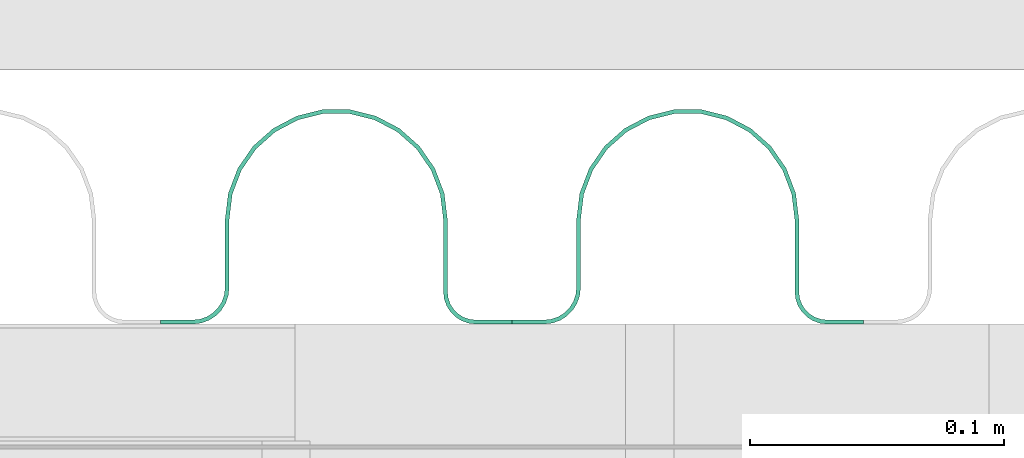
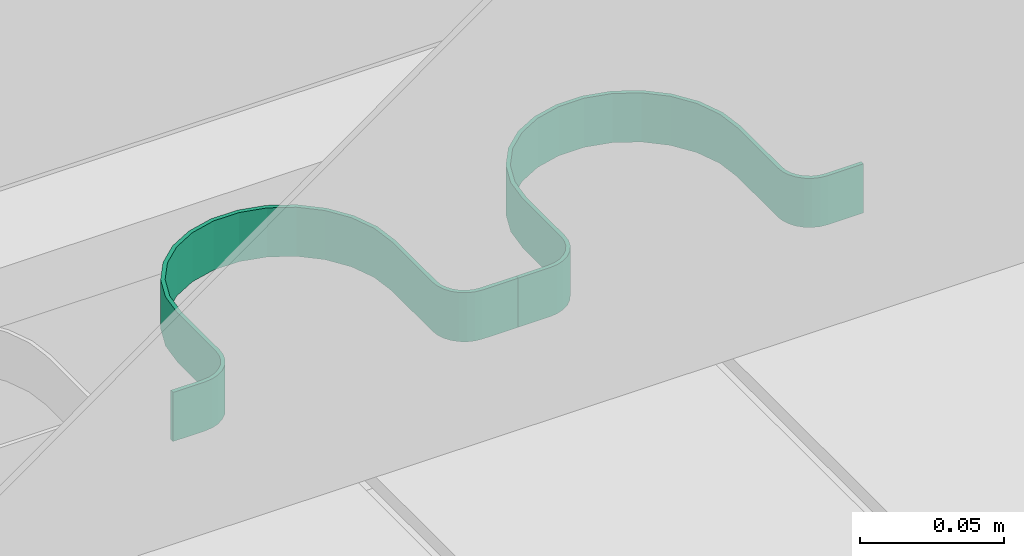
# One storey, part 28 of 33: 2 valves.
"""IFC4 building model written with IfcOpenShell, lengths in feet."""

from ifc_helpers import new_model, entity, si_unit, converted_unit, derived_unit, direction, frame, frame_2d, origin, place, context, subcontext, project, spatial, polyline, circle_curve, parameter, trimmed, segment, composite_curve, outline, extrude, source, transform, mapped, material, type_object, type_shapes, element, save


model = new_model("IFC4")

# Units and contexts
model_context = context("Model", 3, precision=0.0001, world=origin(), true_north=direction((6.12303176911189e-17, 1.0)))
body_context = subcontext(model_context, "Body", "Model", "MODEL_VIEW")
ifc_project = project(units=[converted_unit("LENGTHUNIT", "FOOT", entity("IfcRatioMeasure", 0.3048), si_unit("LENGTHUNIT", "METRE"), dimensions=[1, 0, 0, 0, 0, 0, 0]), converted_unit("AREAUNIT", "SQUARE FOOT", entity("IfcRatioMeasure", 0.09290304), si_unit("AREAUNIT", "SQUARE_METRE"), dimensions=[2, 0, 0, 0, 0, 0, 0]), converted_unit("VOLUMEUNIT", "CUBIC FOOT", entity("IfcRatioMeasure", 0.028316846592), si_unit("VOLUMEUNIT", "CUBIC_METRE"), dimensions=[3, 0, 0, 0, 0, 0, 0]), converted_unit("PLANEANGLEUNIT", "DEGREE", entity("IfcRatioMeasure", 0.0174532925199433), si_unit("PLANEANGLEUNIT", "RADIAN"), dimensions=[0, 0, 0, 0, 0, 0, 0]), si_unit("MASSUNIT", "GRAM", prefix="KILO"), derived_unit("MASSDENSITYUNIT", [(si_unit("MASSUNIT", "GRAM", prefix="KILO"), 1), (si_unit("LENGTHUNIT", "METRE"), -3)]), derived_unit("MOMENTOFINERTIAUNIT", [(si_unit("LENGTHUNIT", "METRE"), 4)]), si_unit("TIMEUNIT", "SECOND"), si_unit("FREQUENCYUNIT", "HERTZ"), si_unit("THERMODYNAMICTEMPERATUREUNIT", "DEGREE_CELSIUS"), derived_unit("THERMALTRANSMITTANCEUNIT", [(si_unit("MASSUNIT", "GRAM", prefix="KILO"), 1), (si_unit("THERMODYNAMICTEMPERATUREUNIT", "KELVIN"), -1), (si_unit("TIMEUNIT", "SECOND"), -3)]), derived_unit("VOLUMETRICFLOWRATEUNIT", [(si_unit("LENGTHUNIT", "METRE"), 3), (si_unit("TIMEUNIT", "SECOND"), -1)]), si_unit("ELECTRICCURRENTUNIT", "AMPERE"), si_unit("ELECTRICVOLTAGEUNIT", "VOLT"), si_unit("POWERUNIT", "WATT"), si_unit("FORCEUNIT", "NEWTON"), si_unit("ILLUMINANCEUNIT", "LUX"), si_unit("LUMINOUSFLUXUNIT", "LUMEN"), si_unit("LUMINOUSINTENSITYUNIT", "CANDELA"), derived_unit("USERDEFINED", [(si_unit("MASSUNIT", "GRAM", prefix="KILO"), -1), (si_unit("LENGTHUNIT", "METRE"), -2), (si_unit("TIMEUNIT", "SECOND"), 3), (si_unit("LUMINOUSFLUXUNIT", "LUMEN"), 1)]), derived_unit("LINEARVELOCITYUNIT", [(si_unit("LENGTHUNIT", "METRE"), 1), (si_unit("TIMEUNIT", "SECOND"), -1)]), si_unit("PRESSUREUNIT", "PASCAL"), derived_unit("USERDEFINED", [(si_unit("LENGTHUNIT", "METRE"), -2), (si_unit("MASSUNIT", "GRAM", prefix="KILO"), 1), (si_unit("TIMEUNIT", "SECOND"), -2)]), derived_unit("LINEARFORCEUNIT", [(si_unit("MASSUNIT", "GRAM", prefix="KILO"), 1), (si_unit("LENGTHUNIT", "METRE"), 1), (si_unit("TIMEUNIT", "SECOND"), -2), (si_unit("LENGTHUNIT", "METRE"), -1)]), derived_unit("PLANARFORCEUNIT", [(si_unit("MASSUNIT", "GRAM", prefix="KILO"), 1), (si_unit("LENGTHUNIT", "METRE"), 1), (si_unit("TIMEUNIT", "SECOND"), -2), (si_unit("LENGTHUNIT", "METRE"), -2)])], contexts=[model_context])

# Site, building, storey
site_placement = place(None, origin())
site = spatial("IfcSite", under=ifc_project, at=site_placement, CompositionType="ELEMENT")
building_placement = place(site_placement, origin())
building = spatial("IfcBuilding", under=site, at=building_placement, CompositionType="ELEMENT")
storey_placement = place(building_placement, frame((0.0, 0.0, 10.0)))
storey = spatial("IfcBuildingStorey", under=building, at=storey_placement, Name="2ND FLOOR", CompositionType="ELEMENT", Elevation=10.0000000000002)

# Valves
ifc_material = material(Name="GALV. U BRACKET AT GALV. PIPE", Category="Materials")
valve_type_1 = type_object("IfcValveType", Name="U BRACKET5:U BRACKET", PredefinedType="NOTDEFINED", material=ifc_material)
shared_shape_1 = source(origin(), body_context, "Body", "SweptSolid", [
    extrude(outline(composite_curve([segment(polyline([(0.0407648216664178, -0.226295029472567), (0.0459731549997509, -0.226295029472567)]), True, "CONTINUOUS"), segment(polyline([(0.0459731549997509, -0.226295029472567), (0.0459731549997509, -0.184628362805825)]), True, "CONTINUOUS"), segment(trimmed(circle_curve(frame_2d((-0.000901845000249146, -0.184628362805825), x_axis=(0.0, 1.0)), 0.046875), [parameter(270.0)], [parameter(2.03555499613665e-13)], True, "PARAMETER"), True, "CONTINUOUS"), segment(polyline([(-0.000901845000249146, -0.137753362805825), (-0.0884402983327046, -0.137753362805825)]), True, "CONTINUOUS"), segment(trimmed(circle_curve(frame_2d((-0.0884402983327037, 0.000651041666515084), x_axis=(0.0, 1.0)), 0.138404404472415), [parameter(2.03555499613665e-13)], [parameter(180.0)], True, "PARAMETER"), False, "CONTINUOUS"), segment(polyline([(-0.0884402983327037, 0.139055446138855), (0.00430648833316294, 0.139055446138855)]), True, "CONTINUOUS"), segment(trimmed(circle_curve(frame_2d((0.00430648833316294, 0.180722112805597), x_axis=(0.0, 1.0)), 0.0416666666666667), [parameter(180.0)], [parameter(270.0)], True, "PARAMETER"), True, "CONTINUOUS"), segment(polyline([(0.0459731549998299, 0.180722112805597), (0.0459731549998308, 0.227597112805597)]), True, "CONTINUOUS"), segment(polyline([(0.0459731549998308, 0.227597112805597), (0.0407648216664969, 0.227597112805597)]), True, "CONTINUOUS"), segment(polyline([(0.0407648216664969, 0.227597112805597), (0.0407648216664969, 0.180722112805597)]), True, "CONTINUOUS"), segment(trimmed(circle_curve(frame_2d((0.00430648833316294, 0.180722112805597), x_axis=(0.0, 1.0)), 0.0364583333333333), [parameter(180.0)], [parameter(270.0)], True, "PARAMETER"), False, "CONTINUOUS"), segment(polyline([(0.00430648833316294, 0.14426377947234), (-0.0884402983327028, 0.14426377947234)]), True, "CONTINUOUS"), segment(trimmed(circle_curve(frame_2d((-0.0884402983327037, 0.000651041666515084), x_axis=(0.0, 1.0)), 0.143612737805749), [parameter(360.0)], [parameter(180.0)], True, "PARAMETER"), True, "CONTINUOUS"), segment(polyline([(-0.0884402983327055, -0.142961696139309), (-0.000901845000249146, -0.142961696139309)]), True, "CONTINUOUS"), segment(trimmed(circle_curve(frame_2d((-0.000901845000249146, -0.184628362805825), x_axis=(0.0, 1.0)), 0.0416666666666667), [parameter(270.0)], [parameter(2.03555499613665e-13)], True, "PARAMETER"), False, "CONTINUOUS"), segment(polyline([(0.0407648216664178, -0.184628362805825), (0.0407648216664178, -0.226295029472567)]), True, "CONTINUOUS")], self_intersect=False)), frame((0.226295029472567, 0.0512069877948296, 0.0), z_axis=(0.0, 0.0, 1.0), x_axis=(0.0, -1.0, 0.0)), (0.0, 0.0, 1.0), 0.0683255255426953),
])
type_shapes(valve_type_1, [shared_shape_1])
valve_1_placement = place(storey_placement, frame((1490.40255519649, 4.11092510371606, 0.757393194068698)))
element("IfcValve", 1, at=valve_1_placement, inside=storey, type_object=valve_type_1, material=ifc_material, Name="U BRACKET5:U BRACKET", ObjectType="U BRACKET5:U BRACKET", PredefinedType="NOTDEFINED", context=body_context, shape_type="MappedRepresentation", body=[
    mapped(shared_shape_1, transform((0.0, 0.0, 0.0), scale=1.0)),
])
valve_type_2 = type_object("IfcValveType", Name="U BRACKET7:U BRACKET", PredefinedType="NOTDEFINED", material=ifc_material)
shared_shape_2 = source(origin(), body_context, "Body", "SweptSolid", [
    extrude(outline(composite_curve([segment(polyline([(0.0407648216664178, -0.226295029472567), (0.0459731549997509, -0.226295029472567)]), True, "CONTINUOUS"), segment(polyline([(0.0459731549997509, -0.226295029472567), (0.0459731549997509, -0.184628362805825)]), True, "CONTINUOUS"), segment(trimmed(circle_curve(frame_2d((-0.000901845000249146, -0.184628362805825), x_axis=(0.0, 1.0)), 0.046875), [parameter(270.0)], [parameter(2.03555499613665e-13)], True, "PARAMETER"), True, "CONTINUOUS"), segment(polyline([(-0.000901845000249146, -0.137753362805825), (-0.0884402983327046, -0.137753362805825)]), True, "CONTINUOUS"), segment(trimmed(circle_curve(frame_2d((-0.0884402983327037, 0.000651041666515084), x_axis=(0.0, 1.0)), 0.138404404472415), [parameter(2.03555499613665e-13)], [parameter(180.0)], True, "PARAMETER"), False, "CONTINUOUS"), segment(polyline([(-0.0884402983327037, 0.139055446138855), (0.00430648833316294, 0.139055446138855)]), True, "CONTINUOUS"), segment(trimmed(circle_curve(frame_2d((0.00430648833316294, 0.180722112805597), x_axis=(0.0, 1.0)), 0.0416666666666667), [parameter(180.0)], [parameter(270.0)], True, "PARAMETER"), True, "CONTINUOUS"), segment(polyline([(0.0459731549998299, 0.180722112805597), (0.0459731549998308, 0.227597112805597)]), True, "CONTINUOUS"), segment(polyline([(0.0459731549998308, 0.227597112805597), (0.0407648216664969, 0.227597112805597)]), True, "CONTINUOUS"), segment(polyline([(0.0407648216664969, 0.227597112805597), (0.0407648216664969, 0.180722112805597)]), True, "CONTINUOUS"), segment(trimmed(circle_curve(frame_2d((0.00430648833316294, 0.180722112805597), x_axis=(0.0, 1.0)), 0.0364583333333333), [parameter(180.0)], [parameter(270.0)], True, "PARAMETER"), False, "CONTINUOUS"), segment(polyline([(0.00430648833316294, 0.14426377947234), (-0.0884402983327028, 0.14426377947234)]), True, "CONTINUOUS"), segment(trimmed(circle_curve(frame_2d((-0.0884402983327037, 0.000651041666515084), x_axis=(0.0, 1.0)), 0.143612737805749), [parameter(360.0)], [parameter(180.0)], True, "PARAMETER"), True, "CONTINUOUS"), segment(polyline([(-0.0884402983327055, -0.142961696139309), (-0.000901845000249146, -0.142961696139309)]), True, "CONTINUOUS"), segment(trimmed(circle_curve(frame_2d((-0.000901845000249146, -0.184628362805825), x_axis=(0.0, 1.0)), 0.0416666666666667), [parameter(270.0)], [parameter(2.03555499613665e-13)], True, "PARAMETER"), False, "CONTINUOUS"), segment(polyline([(0.0407648216664178, -0.184628362805825), (0.0407648216664178, -0.226295029472567)]), True, "CONTINUOUS")], self_intersect=False)), frame((0.226295029472567, 0.0512069877948296, 0.0), z_axis=(0.0, 0.0, 1.0), x_axis=(0.0, -1.0, 0.0)), (0.0, 0.0, 1.0), 0.0683255255426953),
])
type_shapes(valve_type_2, [shared_shape_2])
valve_2_placement = place(storey_placement, frame((1489.94866305421, 4.11092510371607, 0.757393194068696)))
element("IfcValve", 2, at=valve_2_placement, inside=storey, type_object=valve_type_2, material=ifc_material, Name="U BRACKET7:U BRACKET", ObjectType="U BRACKET7:U BRACKET", PredefinedType="NOTDEFINED", context=body_context, shape_type="MappedRepresentation", body=[
    mapped(shared_shape_2, transform((0.0, 0.0, 0.0), scale=1.0)),
])

save(model, "model.ifc")
